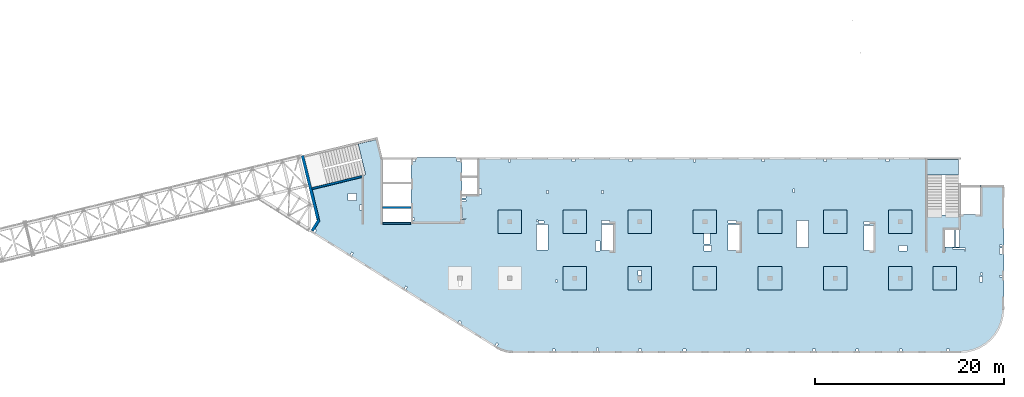
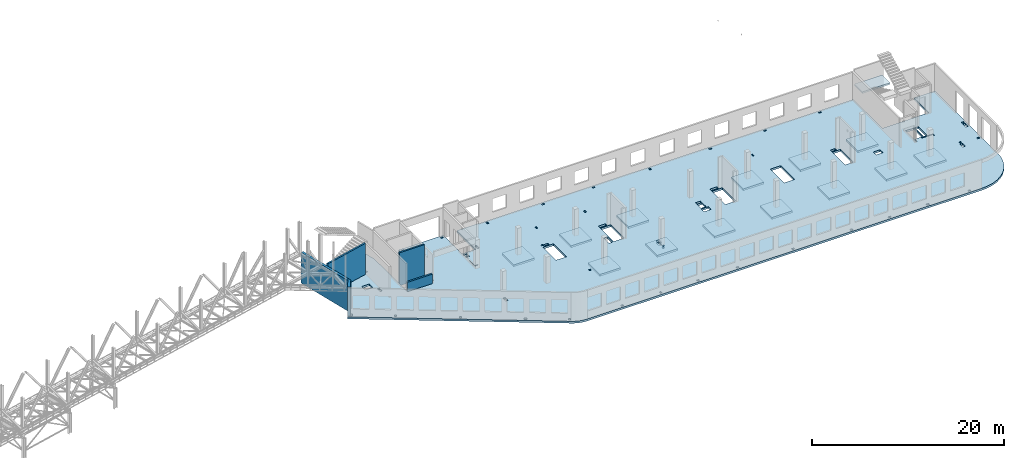
# One storey, part 20 of 93: 16 slabs, 5 walls.
"""IFC4 building model written with IfcOpenShell, lengths in millimetres."""

from ifc_helpers import new_model, entity, si_unit, converted_unit, derived_unit, direction, frame, origin, place, context, subcontext, project, spatial, indexed_curve, outline, extrude, material, type_object, element, save


model = new_model("IFC4")

# Units and contexts
model_context = context("Model", 3, precision=0.01, world=origin(), true_north=direction((6.12303176911189e-17, 1.0)))
plan_context = context("Plan", 3, precision=0.01, world=origin(), true_north=direction((6.12303176911189e-17, 1.0)))
body_context = subcontext(model_context, "Body", "Model", "MODEL_VIEW")
ifc_project = project(units=[si_unit("LENGTHUNIT", "METRE", prefix="MILLI"), si_unit("AREAUNIT", "SQUARE_METRE"), si_unit("VOLUMEUNIT", "CUBIC_METRE"), converted_unit("PLANEANGLEUNIT", "DEGREE", entity("IfcRatioMeasure", 0.0174532925199433), si_unit("PLANEANGLEUNIT", "RADIAN"), dimensions=[0, 0, 0, 0, 0, 0, 0]), si_unit("MASSUNIT", "GRAM", prefix="KILO"), derived_unit("MASSDENSITYUNIT", [(si_unit("MASSUNIT", "GRAM", prefix="KILO"), 1), (si_unit("LENGTHUNIT", "METRE"), -3)]), derived_unit("MOMENTOFINERTIAUNIT", [(si_unit("LENGTHUNIT", "METRE"), 4)]), si_unit("TIMEUNIT", "SECOND"), si_unit("FREQUENCYUNIT", "HERTZ"), si_unit("THERMODYNAMICTEMPERATUREUNIT", "DEGREE_CELSIUS"), derived_unit("THERMALTRANSMITTANCEUNIT", [(si_unit("MASSUNIT", "GRAM", prefix="KILO"), 1), (si_unit("THERMODYNAMICTEMPERATUREUNIT", "KELVIN"), -1), (si_unit("TIMEUNIT", "SECOND"), -3)]), derived_unit("VOLUMETRICFLOWRATEUNIT", [(si_unit("LENGTHUNIT", "METRE"), 3), (si_unit("TIMEUNIT", "SECOND"), -1)]), derived_unit("MASSFLOWRATEUNIT", [(si_unit("MASSUNIT", "GRAM", prefix="KILO"), 1), (si_unit("TIMEUNIT", "SECOND"), -1)]), derived_unit("ROTATIONALFREQUENCYUNIT", [(si_unit("TIMEUNIT", "SECOND"), -1)]), si_unit("ELECTRICCURRENTUNIT", "AMPERE"), si_unit("ELECTRICVOLTAGEUNIT", "VOLT"), si_unit("POWERUNIT", "WATT"), si_unit("FORCEUNIT", "NEWTON", prefix="KILO"), si_unit("ILLUMINANCEUNIT", "LUX"), si_unit("LUMINOUSFLUXUNIT", "LUMEN"), si_unit("LUMINOUSINTENSITYUNIT", "CANDELA"), derived_unit("USERDEFINED", [(si_unit("MASSUNIT", "GRAM", prefix="KILO"), -1), (si_unit("LENGTHUNIT", "METRE"), -2), (si_unit("TIMEUNIT", "SECOND"), 3), (si_unit("LUMINOUSFLUXUNIT", "LUMEN"), 1)]), derived_unit("LINEARVELOCITYUNIT", [(si_unit("LENGTHUNIT", "METRE"), 1), (si_unit("TIMEUNIT", "SECOND"), -1)]), si_unit("PRESSUREUNIT", "PASCAL"), derived_unit("USERDEFINED", [(si_unit("LENGTHUNIT", "METRE"), -2), (si_unit("MASSUNIT", "GRAM", prefix="KILO"), 1), (si_unit("TIMEUNIT", "SECOND"), -2)]), derived_unit("LINEARFORCEUNIT", [(si_unit("MASSUNIT", "GRAM", prefix="KILO"), 1), (si_unit("LENGTHUNIT", "METRE"), 1), (si_unit("TIMEUNIT", "SECOND"), -2), (si_unit("LENGTHUNIT", "METRE"), -1)]), derived_unit("PLANARFORCEUNIT", [(si_unit("MASSUNIT", "GRAM", prefix="KILO"), 1), (si_unit("LENGTHUNIT", "METRE"), 1), (si_unit("TIMEUNIT", "SECOND"), -2), (si_unit("LENGTHUNIT", "METRE"), -2)])], contexts=[model_context, plan_context])

# Site, building, storey
site_placement = place(None, origin())
site = spatial("IfcSite", under=ifc_project, at=site_placement, CompositionType="ELEMENT")
building_placement = place(site_placement, origin())
building = spatial("IfcBuilding", under=site, at=building_placement, CompositionType="ELEMENT")
storey_placement = place(building_placement, frame((0.0, 0.0, 15900.0)))
storey = spatial("IfcBuildingStorey", under=building, at=storey_placement, CompositionType="ELEMENT", Elevation=15900.0)

# Slabs
ifc_material = material()
slab_type_1 = type_object("IfcSlabType", PredefinedType="FLOOR", material=ifc_material)
slab_1_placement = place(storey_placement, origin())
element("IfcSlab", 1, at=slab_1_placement, inside=storey, type_object=slab_type_1, material=ifc_material, PredefinedType="FLOOR", context=body_context, shape_type="SweptSolid", body=[
    extrude(outline(indexed_curve([(-11615.3456191022, -15866.2384672249), (-11461.2227621515, -15956.6617307079), (-11302.2940263976, -16038.3432987954), (-11139.0547290428, -16111.0286027615), (-10972.0136215827, -16174.4911116315), (-10801.6913042325, -16228.5330381886), (-10628.6186034238, -16272.985955397), (-10453.3349174317, -16307.7113213217), (-10276.3865352866, -16332.6009109081), (-10098.3249342096, -16347.5771532763), (-9919.70506087959, -16352.5933734784), (37585.2949391216, -16352.5933734786), (38304.8933503634, -16295.9597502856), (39006.7728605103, -16127.4533884657), (39673.6508666178, -15851.2234738877), (40289.1066189344, -15474.0717038028), (40837.9855542575, -15005.2848064856), (41306.7724515748, -14456.4058711625), (41683.9242216596, -13840.9501188459), (41960.1541362377, -13174.0721127383), (42128.6604980575, -12472.1926025915), (42185.2941212505, -11752.5941913496), (42185.2941212505, 1417.40662652148), (39685.2941212505, 1417.40662652149), (39685.2941212505, -1682.59337347851), (37385.2949391216, -1682.59337347851), (37385.2949391216, -1722.59337347848), (34045.2949391217, -1722.59337347847), (34045.2949391217, 4347.4072658887), (-13659.7050608784, 4347.40726588886), (-13659.7050608784, 447.406626521855), (-15284.7050608784, 447.406626521859), (-15284.7050608784, 4347.40726588869), (-20684.7050608784, 4347.40726588871), (-20684.7050608784, -2502.5933734781), (-23684.7050608784, -2502.59337347809), (-23684.7050608784, 4347.40726588869), (-23734.0606732206, 4347.40726588869), (-24254.10794231, 6480.84192351009), (-24448.4183539383, 6433.47670491202), (-24401.0531353402, 6239.16629328373), (-26276.1486075532, 5782.09193381237), (-25485.1529405355, 2537.12235056864), (-31479.6214345329, 1075.90723492907), (-30648.3195083992, -2334.4141830962), (-31384.8454167592, -3513.12502953493), (-11615.3456191022, -15866.2384672249)], self_intersect=False), holes=[indexed_curve([(-26424.7050608784, -192.593373478052), (-27324.7050608784, -192.593373478052), (-27324.7050608784, 507.406626521949), (-26424.7050608784, 507.406626521947), (-26424.7050608784, -192.593373478052)], self_intersect=False), indexed_curve([(-25884.7050608784, -667.593373478048), (-25884.7050608784, -1227.59337347805), (-26134.7050608784, -1227.59337347805), (-26134.7050608784, -667.593373478048), (-25884.7050608784, -667.593373478048)], self_intersect=False), indexed_curve([(-30865.4736804199, -3248.07220556975), (-30695.8631316644, -3354.05457085215), (-30854.836679588, -3608.47039398543), (-31024.4472283436, -3502.48802870303), (-30865.4736804199, -3248.07220556975)], self_intersect=False), indexed_curve([(-26955.9505316053, -5690.96572532919), (-26786.3399828498, -5796.94809061159), (-26945.3135307734, -6051.36391374487), (-27114.9240795289, -5945.38154846246), (-26955.9505316053, -5690.96572532919)], self_intersect=False), indexed_curve([(-21223.1139836689, -9273.16967187448), (-21053.5034349134, -9379.15203715688), (-21212.476982837, -9633.56786029016), (-21382.0875315925, -9527.58549500775), (-21223.1139836689, -9273.16967187448)], self_intersect=False), indexed_curve([(-15551.7491458115, -12934.8797745334), (-15297.3333226782, -13093.853322457), (-15403.3156879606, -13263.4638712125), (-15657.7315110939, -13104.4903232889), (-15551.7491458115, -12934.8797745334)], self_intersect=False), indexed_curve([(-11580.7542869179, -15298.2671381792), (-11411.1437381624, -15404.2495034616), (-11570.117286086, -15658.6653265949), (-11739.7278348415, -15552.6829613125), (-11580.7542869179, -15298.2671381792)], self_intersect=False), indexed_curve([(-5384.7050608784, -16152.5933734782), (-5684.7050608784, -16152.5933734782), (-5684.7050608784, -15952.5933734782), (-5384.7050608784, -15952.5933734782), (-5384.7050608784, -16152.5933734782)], self_intersect=False), indexed_curve([(-789.705060878393, -16152.5933734782), (-989.705060878395, -16152.5933734782), (-989.705060878386, -15852.5933734782), (-789.705060878388, -15852.5933734782), (-789.705060878393, -16152.5933734782)], self_intersect=False), indexed_curve([(3735.29493912161, -16152.5933734782), (3435.29493912161, -16152.5933734782), (3435.29493912161, -15952.5933734782), (3735.29493912161, -15952.5933734782), (3735.29493912161, -16152.5933734782)], self_intersect=False), indexed_curve([(8485.29493912161, -16152.5933734783), (8185.29493912161, -16152.5933734782), (8185.29493912161, -15952.5933734782), (8485.29493912161, -15952.5933734783), (8485.29493912161, -16152.5933734783)], self_intersect=False), indexed_curve([(15185.2949391216, -16152.5933734783), (14885.2949391216, -16152.5933734782), (14885.2949391216, -15952.5933734783), (15185.2949391216, -15952.5933734783), (15185.2949391216, -16152.5933734783)], self_intersect=False), indexed_curve([(22185.2949391216, -16152.5933734783), (21885.2949391216, -16152.5933734783), (21885.2949391216, -15952.5933734783), (22185.2949391216, -15952.5933734783), (22185.2949391216, -16152.5933734783)], self_intersect=False), indexed_curve([(26785.2949391216, -16152.5933734783), (26485.2949391216, -16152.5933734783), (26485.2949391216, -15952.5933734783), (26785.2949391216, -15952.5933734783), (26785.2949391216, -16152.5933734783)], self_intersect=False), indexed_curve([(31385.2949391216, -16152.5933734783), (31085.2949391216, -16152.5933734783), (31085.2949391216, -15952.5933734783), (31385.2949391216, -15952.5933734783), (31385.2949391216, -16152.5933734783)], self_intersect=False), indexed_curve([(36385.2949391216, -16152.5933734783), (36085.2949391216, -16152.5933734783), (36085.2949391216, -15952.5933734783), (36385.2949391216, -15952.5933734783), (36385.2949391216, -16152.5933734783)], self_intersect=False), indexed_curve([(-20184.7050608784, 4147.4072658887), (-20184.7050608784, 3947.4072658887), (-20484.7050608784, 3947.40726588869), (-20484.7050608784, 4147.4072658887), (-20184.7050608784, 4147.4072658887)], self_intersect=False), indexed_curve([(-20284.7050608784, -2252.59337347809), (-20484.7050608784, -2252.59337347809), (-20484.7050608784, -2052.59337347809), (-20284.7050608784, -2052.59337347809), (-20284.7050608784, -2252.59337347809)], self_intersect=False), indexed_curve([(-15784.7050608784, 4147.4072658887), (-15484.7050608784, 4147.4072658887), (-15484.7050608784, 3947.4072658887), (-15784.7050608784, 3947.4072658887), (-15784.7050608784, 4147.4072658887)], self_intersect=False), indexed_curve([(-14854.7050608784, 247.406626521861), (-14854.7050608784, 47.4066265218589), (-15284.7050608784, 47.4066265218589), (-15284.7050608784, 247.406626521859), (-14854.7050608784, 247.406626521861)], self_intersect=False), indexed_curve([(-14854.7050608784, -177.593373478142), (-14854.7050608784, -337.59337347814), (-15284.7050608784, -337.59337347814), (-15284.7050608784, -177.593373478142), (-14854.7050608784, -177.593373478142)], self_intersect=False), indexed_curve([(-15284.7050608784, -2182.59337347814), (-15284.7050608784, -992.593373478139), (-15204.7050608784, -992.593373478139), (-15204.7050608784, -2102.59337347814), (-14864.7050608784, -2102.59337347814), (-14864.7050608784, -2182.59337347814), (-15284.7050608784, -2182.59337347814)], self_intersect=False), indexed_curve([(-13209.7050608784, 447.406626521855), (-13459.7050608784, 447.406626521855), (-13459.7050608784, 1007.40662652186), (-13209.7050608784, 1007.40662652186), (-13209.7050608784, 447.406626521855)], self_intersect=False), indexed_curve([(-10314.7050608784, 4147.4072658887), (-10214.7050608784, 4147.4072658887), (-10114.7050608784, 4147.40662652183), (-10114.7050608784, 3847.40726588869), (-10314.7050608784, 3847.40726588869), (-10314.7050608784, 4147.4072658887)], self_intersect=False), indexed_curve([(-3614.70506087836, 4147.40662652179), (-3314.70506087836, 4147.40662652179), (-3314.70506087836, 3947.40662652179), (-3614.70506087836, 3947.40662652179), (-3614.70506087836, 4147.40662652179)], self_intersect=False), indexed_curve([(2460.29493912165, 4147.40662652177), (2760.29493912165, 4147.40662652177), (2760.29493912164, 3947.40662652177), (2460.29493912164, 3947.40662652176), (2460.29493912165, 4147.40662652177)], self_intersect=False), indexed_curve([(16510.2949391216, 4147.40662652173), (16810.2949391216, 4147.40662652172), (16810.2949391216, 3947.40662652171), (16510.2949391216, 3947.40662652172), (16510.2949391216, 4147.40662652173)], self_intersect=False), indexed_curve([(9260.29493912165, 4147.4066265217), (9460.29493912165, 4147.4066265217), (9460.29493912166, 3847.4066265217), (9260.29493912165, 3847.4066265217), (9260.29493912165, 4147.4066265217)], self_intersect=False), indexed_curve([(23085.2949391216, 4147.40662652169), (23385.2949391216, 4147.40662652169), (23385.2949391216, 3947.4066265217), (23085.2949391216, 3947.4066265217), (23085.2949391216, 4147.40662652169)], self_intersect=False), indexed_curve([(29685.2949391216, 4147.40662652168), (29985.2949391216, 4147.40662652167), (29985.2949391216, 3947.40662652167), (29685.2949391216, 3947.40662652167), (29685.2949391216, 4147.40662652168)], self_intersect=False), indexed_curve([(-6114.70506087836, 847.407265888692), (-6114.70506087836, 527.407265888689), (-6314.70506087837, 527.407265888691), (-6314.70506087837, 847.407265888695), (-6114.70506087836, 847.407265888692)], self_intersect=False), indexed_curve([(-264.705060878365, 867.407265888811), (-264.70506087836, 507.407265888813), (-464.705060878358, 507.407265888813), (-464.705060878358, 867.407265888811), (-264.705060878365, 867.407265888811)], self_intersect=False), indexed_curve([(19975.2949391216, 997.407265888704), (19975.2949391216, 647.407265888701), (19825.2949391216, 647.407265888701), (19825.2949391216, 997.407265888704), (19975.2949391216, 997.407265888704)], self_intersect=False), indexed_curve([(37055.2949391217, -5127.59337347849), (37055.2949391217, -3322.59337347848), (37385.2949391216, -3322.59337347849), (37445.2949391217, -3322.59337347849), (37445.2949391217, -5127.59337347849), (37055.2949391217, -5127.59337347849)], self_intersect=False), indexed_curve([(35975.2949391217, -5247.59337347849), (35975.2949391217, -5587.59337347849), (35895.2949391217, -5587.59337347849), (35895.2949391217, -5247.59337347849), (35975.2949391217, -5247.59337347849)], self_intersect=False), indexed_curve([(38095.2949391216, -5247.59337347848), (38095.2949391216, -5587.59337347848), (38015.2949391216, -5587.59337347849), (38015.2949391216, -5327.59337347848), (36715.2949391216, -5327.59337347848), (36715.2949391216, -5247.59337347849), (38095.2949391216, -5247.59337347848)], self_intersect=False), indexed_curve([(41685.2941212505, -8342.59337347853), (41685.2941212505, -8142.59337347853), (41985.2941212505, -8142.59337347853), (41985.2941212505, -8342.59337347853), (41685.2941212505, -8342.59337347853)], self_intersect=False), indexed_curve([(41685.2941212505, -5102.59337347853), (41685.2941212505, -4902.59337347852), (41985.2941212505, -4902.59337347853), (41985.2941212505, -5102.59337347853), (41685.2941212505, -5102.59337347853)], self_intersect=False), indexed_curve([(41685.2941212505, -5867.59337347854), (41685.2941212505, -5267.59337347853), (41985.2941212505, -5267.59337347854), (41985.2941212505, -5867.59337347854), (41685.2941212505, -5867.59337347854)], self_intersect=False), indexed_curve([(39895.2941212505, -8272.5933734785), (39895.2941212505, -8852.59337347852), (39595.2941212505, -8852.59337347852), (39595.2941212505, -8272.59337347851), (39895.2941212505, -8272.5933734785)], self_intersect=False), indexed_curve([(39905.2941212505, -7892.59337347851), (39905.2941212505, -8092.59337347851), (39705.2941212505, -8092.59337347851), (39705.2941212505, -7892.5933734785), (39905.2941212505, -7892.59337347851)], self_intersect=False), indexed_curve([(31900.2949391216, -4967.59337347845), (31900.2949391216, -5567.59337347845), (31070.2949391216, -5567.59337347845), (31070.2949391216, -4967.59337347845), (31900.2949391216, -4967.59337347845)], self_intersect=False), indexed_curve([(27345.2949391216, -5527.59337347843), (27345.2949391216, -2857.59337347842), (28345.2949391217, -2857.59337347842), (28345.2949391217, -5527.59337347844), (27345.2949391216, -5527.59337347843)], self_intersect=False), indexed_curve([(27345.2949391216, -2452.59337347842), (27945.2949391216, -2452.59337347842), (27945.2949391216, -2737.59337347842), (27345.2949391216, -2737.59337347842), (27345.2949391216, -2452.59337347842)], self_intersect=False), indexed_curve([(21465.2949391216, -2317.59337347838), (21465.2949391216, -5177.59337347839), (20205.2949391216, -5177.59337347839), (20205.2949391216, -2317.59337347838), (21465.2949391216, -2317.59337347838)], self_intersect=False), indexed_curve([(12925.2949391216, -5527.59322391854), (12925.2949391216, -2752.59322391854), (14185.2949391216, -2752.59322391854), (14185.2949391216, -5527.59322391853), (12925.2949391216, -5527.59322391854)], self_intersect=False), indexed_curve([(12925.2949391216, -2602.59337347834), (12925.2949391216, -2312.59337347833), (13785.2949391216, -2312.59337347833), (13785.2949391216, -2602.59337347834), (12925.2949391216, -2602.59337347834)], self_intersect=False), indexed_curve([(10395.2949391217, -3702.59337347839), (10485.2949391216, -3702.59337347838), (11015.2949391216, -3702.59337347839), (11015.2949391216, -4822.59337347839), (10395.2949391217, -4822.59337347839), (10395.2949391217, -3702.59337347839)], self_intersect=False), indexed_curve([(10370.2949391216, -4967.59337347839), (11200.2949391216, -4967.59337347839), (11200.2949391216, -5567.59337347838), (10370.2949391216, -5567.59337347839), (10370.2949391216, -4967.59337347839)], self_intersect=False), indexed_curve([(3485.29493912162, -8702.59337347826), (3585.29493912162, -8702.59337347826), (3685.29493912163, -8702.59337347826), (3685.29493912163, -8902.59337347827), (3485.29493912163, -8902.59337347827), (3485.29493912162, -8702.59337347826)], self_intersect=False), indexed_curve([(3405.29493912162, -8162.59337347827), (3405.29493912162, -7652.59337347826), (3735.29493912162, -7652.59337347827), (3735.29493912162, -8162.59337347826), (3405.29493912162, -8162.59337347827)], self_intersect=False), indexed_curve([(-474.705060878365, -5527.5932239185), (-474.705060878365, -2752.5932239185), (785.29493912163, -2752.5932239185), (785.294939121635, -5527.59322391849), (-474.705060878365, -5527.5932239185)], self_intersect=False), indexed_curve([(-474.705060878365, -2312.59337347824), (385.29493912163, -2312.59337347824), (385.294939121626, -2632.59337347824), (-474.705060878369, -2632.59337347824), (-474.705060878365, -2312.59337347824)], self_intersect=False), indexed_curve([(-1094.70506087836, -5567.5932239185), (-1094.70506087837, -4477.5932239185), (-634.705060878363, -4477.5932239185), (-634.705060878363, -5567.5932239185), (-1094.70506087836, -5567.5932239185)], self_intersect=False), indexed_curve([(-5134.70506087838, -8662.5933734782), (-5134.70506087839, -8862.5933734782), (-5334.70506087839, -8862.5933734782), (-5334.70506087839, -8662.5933734782), (-5134.70506087838, -8662.5933734782)], self_intersect=False), indexed_curve([(-6134.70506087837, -2752.59337347818), (-6134.70506087837, -5462.59337347818), (-7394.70506087837, -5462.59337347818), (-7394.70506087837, -2752.59337347818), (-6134.70506087837, -2752.59337347818)], self_intersect=False), indexed_curve([(-7194.70506087837, -2462.59337347819), (-7394.70506087837, -2462.59337347819), (-7394.70506087837, -2272.59337347818), (-7194.70506087837, -2272.59337347818), (-7194.70506087837, -2462.59337347819)], self_intersect=False), indexed_curve([(-6594.70506087837, -2632.59337347819), (-7154.70506087837, -2632.59337347819), (-7154.70506087837, -2382.5933734782), (-6594.70506087837, -2382.5933734782), (-6594.70506087837, -2632.59337347819)], self_intersect=False), indexed_curve([(36935.2949391217, -3322.59337347849), (36935.2949391217, -5127.59337347849), (35895.2949391217, -5127.59337347849), (35895.2949391217, -3322.59337347849), (36935.2949391217, -3322.59337347849)], self_intersect=False), indexed_curve([(-15644.7050608784, -8702.59337347814), (-15484.7050608784, -8702.59337347813), (-15394.7050608784, -8702.59337347813), (-15394.7050608784, -9262.59337347813), (-15644.7050608784, -9262.59337347814), (-15644.7050608784, -8702.59337347814)], self_intersect=False)]), frame((31384.7053294331, 16152.592599834, -400.0)), (0.0, 0.0, 1.0), 249.999999999999),
])
slab_type_2 = type_object("IfcSlabType", PredefinedType="FLOOR", material=ifc_material)
slab_2_placement = place(storey_placement, origin())
element("IfcSlab", 2, at=slab_2_placement, inside=storey, type_object=slab_type_2, material=ifc_material, PredefinedType="FLOOR", context=body_context, shape_type="SweptSolid", body=[
    extrude(outline(indexed_curve([(-1250.0, -1250.0), (1250.0, -1250.0), (1250.0, 1250.0), (-1250.0, 1250.0), (-1250.0, -1250.0)], self_intersect=False)), frame((28070.0002685547, 7699.9992263558, -400.0), z_axis=(0.0, 0.0, -1.0), x_axis=(0.0, 1.0, 0.0)), (0.0, 0.0, 1.0), 249.999999999999),
])
slab_type_3 = type_object("IfcSlabType", PredefinedType="FLOOR", material=ifc_material)
slab_3_placement = place(storey_placement, origin())
element("IfcSlab", 3, at=slab_3_placement, inside=storey, type_object=slab_type_3, material=ifc_material, PredefinedType="FLOOR", context=body_context, shape_type="SweptSolid", body=[
    extrude(outline(indexed_curve([(-999.999999999999, -1250.00000000001), (1500.0, -1250.00000000001), (1500.0, 1250.0), (-999.999999999999, 1250.0), (-1000.0, -6.064055924071e-12), (-999.999999999999, -1250.00000000001)], self_intersect=False), holes=[indexed_curve([(500.000000000073, 99.9999999999998), (700.000000000076, 100.0), (700.000000000076, -100.000000000002), (500.000000000074, -100.000000000002), (500.000000000073, 99.9999999999998)], self_intersect=False), indexed_curve([(-549.999999999928, 149.999999999991), (-39.9999999999262, 149.999999999992), (-39.9999999999256, -180.000000000007), (-549.999999999928, -180.000000000008), (-549.999999999928, 149.999999999991)], self_intersect=False)]), frame((34970.0002685547, 7949.99922635578, -650.0), z_axis=(0.0, 0.0, 1.0), x_axis=(0.0, -1.0, 0.0)), (0.0, 0.0, 1.0), 249.999999999999),
])
slab_type_4 = type_object("IfcSlabType", PredefinedType="FLOOR", material=ifc_material)
slab_4_placement = place(storey_placement, origin())
element("IfcSlab", 4, at=slab_4_placement, inside=storey, type_object=slab_type_4, material=ifc_material, PredefinedType="FLOOR", context=body_context, shape_type="SweptSolid", body=[
    extrude(outline(indexed_curve([(-1250.0, -1250.0), (1250.0, -1250.0), (1250.0, 1250.0), (-1250.0, 1250.0), (-1250.0, -1250.0)], self_intersect=False)), frame((41870.0002685547, 7699.99922635575, -400.0), z_axis=(0.0, 0.0, -1.0), x_axis=(0.0, 1.0, 0.0)), (0.0, 0.0, 1.0), 249.999999999999),
])
slab_type_5 = type_object("IfcSlabType", PredefinedType="FLOOR", material=ifc_material)
slab_5_placement = place(storey_placement, origin())
element("IfcSlab", 5, at=slab_5_placement, inside=storey, type_object=slab_type_5, material=ifc_material, PredefinedType="FLOOR", context=body_context, shape_type="SweptSolid", body=[
    extrude(outline(indexed_curve([(-1250.0, -1250.0), (1250.0, -1250.0), (1250.0, 1250.0), (-1250.0, 1250.0), (-1250.0, -1250.0)], self_intersect=False)), frame((48770.0002685547, 7699.99922635573, -400.0), z_axis=(0.0, 0.0, -1.0), x_axis=(0.0, 1.0, 0.0)), (0.0, 0.0, 1.0), 249.999999999999),
])
slab_type_6 = type_object("IfcSlabType", PredefinedType="FLOOR", material=ifc_material)
slab_6_placement = place(storey_placement, origin())
element("IfcSlab", 6, at=slab_6_placement, inside=storey, type_object=slab_type_6, material=ifc_material, PredefinedType="FLOOR", context=body_context, shape_type="SweptSolid", body=[
    extrude(outline(indexed_curve([(-1250.0, -1249.99999999999), (1250.0, -1249.99999999999), (1250.0, 1250.00000000001), (-1250.0, 1250.00000000001), (-1250.0, -1249.99999999999)], self_intersect=False)), frame((55670.0002685547, 7699.99922635571, -400.0), z_axis=(0.0, 0.0, -1.0), x_axis=(0.0, 1.0, 0.0)), (0.0, 0.0, 1.0), 249.999999999999),
])
slab_type_7 = type_object("IfcSlabType", PredefinedType="FLOOR", material=ifc_material)
slab_7_placement = place(storey_placement, origin())
element("IfcSlab", 7, at=slab_7_placement, inside=storey, type_object=slab_type_7, material=ifc_material, PredefinedType="FLOOR", context=body_context, shape_type="SweptSolid", body=[
    extrude(outline(indexed_curve([(-1250.0, -1250.0), (1250.0, -1250.0), (1250.0, 1250.0), (-1250.0, 1250.0), (-1250.0, -1250.0)], self_intersect=False)), frame((62570.0002685547, 7699.99922635568, -400.0), z_axis=(0.0, 0.0, -1.0), x_axis=(0.0, 1.0, 0.0)), (0.0, 0.0, 1.0), 249.999999999999),
])
slab_type_8 = type_object("IfcSlabType", PredefinedType="FLOOR", material=ifc_material)
slab_8_placement = place(storey_placement, origin())
element("IfcSlab", 8, at=slab_8_placement, inside=storey, type_object=slab_type_8, material=ifc_material, PredefinedType="FLOOR", context=body_context, shape_type="SweptSolid", body=[
    extrude(outline(indexed_curve([(-1250.0, -1249.99999999999), (1250.0, -1249.99999999999), (1250.0, 1250.00000000001), (-1250.0, 1250.00000000001), (-1250.0, -1249.99999999999)], self_intersect=False)), frame((67270.0002685547, 7699.99922635567, -400.0), z_axis=(0.0, 0.0, -1.0), x_axis=(0.0, 1.0, 0.0)), (0.0, 0.0, 1.0), 249.999999999999),
])
slab_type_9 = type_object("IfcSlabType", PredefinedType="FLOOR", material=ifc_material)
slab_9_placement = place(storey_placement, origin())
element("IfcSlab", 9, at=slab_9_placement, inside=storey, type_object=slab_type_9, material=ifc_material, PredefinedType="FLOOR", context=body_context, shape_type="SweptSolid", body=[
    extrude(outline(indexed_curve([(-1250.0, -1250.0), (1250.0, -1250.0), (1250.0, 1250.0), (-1250.0, 1250.0), (-1250.0, -1250.0)], self_intersect=False)), frame((62570.0002685547, 13699.9992263555, -400.0), z_axis=(0.0, 0.0, -1.0), x_axis=(0.0, 1.0, 0.0)), (0.0, 0.0, 1.0), 249.999999999999),
])
slab_type_10 = type_object("IfcSlabType", PredefinedType="FLOOR", material=ifc_material)
slab_10_placement = place(storey_placement, origin())
element("IfcSlab", 10, at=slab_10_placement, inside=storey, type_object=slab_type_10, material=ifc_material, PredefinedType="FLOOR", context=body_context, shape_type="SweptSolid", body=[
    extrude(outline(indexed_curve([(-1250.0, -1250.0), (1250.0, -1250.0), (1250.0, 1250.0), (-1250.0, 1250.0), (-1250.0, -1250.0)], self_intersect=False)), frame((55670.0002685547, 13699.9992263555, -400.0), z_axis=(0.0, 0.0, -1.0), x_axis=(0.0, 1.0, 0.0)), (0.0, 0.0, 1.0), 249.999999999999),
])
slab_type_11 = type_object("IfcSlabType", PredefinedType="FLOOR", material=ifc_material)
slab_11_placement = place(storey_placement, origin())
element("IfcSlab", 11, at=slab_11_placement, inside=storey, type_object=slab_type_11, material=ifc_material, PredefinedType="FLOOR", context=body_context, shape_type="SweptSolid", body=[
    extrude(outline(indexed_curve([(-1250.0, -1250.0), (1250.0, -1250.0), (1250.0, 1250.0), (-1250.0, 1250.0), (-1250.0, -1250.0)], self_intersect=False)), frame((48770.0002685547, 13699.9992263556, -400.0), z_axis=(0.0, 0.0, -1.0), x_axis=(0.0, 1.0, 0.0)), (0.0, 0.0, 1.0), 249.999999999999),
])
slab_type_12 = type_object("IfcSlabType", PredefinedType="FLOOR", material=ifc_material)
slab_12_placement = place(storey_placement, origin())
element("IfcSlab", 12, at=slab_12_placement, inside=storey, type_object=slab_type_12, material=ifc_material, PredefinedType="FLOOR", context=body_context, shape_type="SweptSolid", body=[
    extrude(outline(indexed_curve([(-1250.0, -1250.0), (1250.0, -1250.0), (1250.0, 1250.0), (-1250.0, 1250.0), (-1250.0, -1250.0)], self_intersect=False)), frame((41870.0002685547, 13699.9992263556, -400.0), z_axis=(0.0, 0.0, -1.0), x_axis=(0.0, 1.0, 0.0)), (0.0, 0.0, 1.0), 249.999999999999),
])
slab_type_13 = type_object("IfcSlabType", PredefinedType="FLOOR", material=ifc_material)
slab_13_placement = place(storey_placement, origin())
element("IfcSlab", 13, at=slab_13_placement, inside=storey, type_object=slab_type_13, material=ifc_material, PredefinedType="FLOOR", context=body_context, shape_type="SweptSolid", body=[
    extrude(outline(indexed_curve([(-1250.0, -1250.0), (1250.0, -1250.0), (1250.0, 1250.0), (-1250.0, 1250.0), (-1250.0, -1250.0)], self_intersect=False)), frame((34970.0002685547, 13699.9992263556, -400.0), z_axis=(0.0, 0.0, -1.0), x_axis=(0.0, 1.0, 0.0)), (0.0, 0.0, 1.0), 249.999999999999),
])
slab_type_14 = type_object("IfcSlabType", PredefinedType="FLOOR", material=ifc_material)
slab_14_placement = place(storey_placement, origin())
element("IfcSlab", 14, at=slab_14_placement, inside=storey, type_object=slab_type_14, material=ifc_material, PredefinedType="FLOOR", context=body_context, shape_type="SweptSolid", body=[
    extrude(outline(indexed_curve([(-1250.0, -1250.0), (1250.0, -1250.0), (1250.0, 1250.0), (-1250.0, 1250.0), (-1250.0, -1250.0)], self_intersect=False)), frame((28070.0002685547, 13699.9992263556, -400.0), z_axis=(0.0, 0.0, -1.0), x_axis=(0.0, 1.0, 0.0)), (0.0, 0.0, 1.0), 249.999999999999),
])
slab_type_15 = type_object("IfcSlabType", PredefinedType="FLOOR", material=ifc_material)
slab_15_placement = place(storey_placement, origin())
element("IfcSlab", 15, at=slab_15_placement, inside=storey, type_object=slab_type_15, material=ifc_material, PredefinedType="FLOOR", context=body_context, shape_type="SweptSolid", body=[
    extrude(outline(indexed_curve([(-1250.0, -1250.0), (1250.0, -1250.0), (1250.0, 1250.0), (-1250.0, 1250.0), (-1250.0, -1250.0)], self_intersect=False)), frame((21170.0002685547, 13699.9992263556, -400.0), z_axis=(0.0, 0.0, -1.0), x_axis=(0.0, 1.0, 0.0)), (0.0, 0.0, 1.0), 249.999999999999),
])
slab_type_16 = type_object("IfcSlabType", PredefinedType="FLOOR", material=ifc_material)
slab_16_placement = place(storey_placement, origin())
element("IfcSlab", 16, at=slab_16_placement, inside=storey, type_object=slab_type_16, material=ifc_material, PredefinedType="FLOOR", context=body_context, shape_type="SweptSolid", body=[
    extrude(outline(indexed_curve([(-834.999999999999, -1670.00000000001), (835.000000000001, -1670.00000000001), (835.000000000001, 1670.00000000002), (-834.999999999999, 1670.00000000002), (-834.999999999999, -1670.00000000001)], self_intersect=False)), frame((67100.0002685547, 19464.999226356, 1920.0), z_axis=(0.0, 0.0, -1.0), x_axis=(0.0, 1.0, 0.0)), (0.0, 0.0, 1.0), 200.0),
])

# Walls
wall_type_1 = type_object("IfcWallType", PredefinedType="STANDARD")
wall_1_placement = place(storey_placement, frame((220.235605211588, 17202.3781658972, -150.0), z_axis=(0.0, 0.0, 1.0), x_axis=(0.971552058141473, 0.236826092990338, 0.0)))
element("IfcWall", 17, at=wall_1_placement, inside=storey, type_object=wall_type_1, material=ifc_material, PredefinedType="NOTDEFINED", context=body_context, shape_type="SweptSolid", body=[
    extrude(outline(indexed_curve([(5409.98499256816, -99.9999999999997), (5458.73710852649, 100.000000000002), (6.34492458573277e-13, 100.000000000002), (1.7427392862146e-12, -99.9999999999982), (5409.98499256816, -99.9999999999997)], self_intersect=False)), origin(), (0.0, 0.0, 1.0), 3950.0),
])
wall_2_placement = place(storey_placement, frame((7700.00026855469, 15199.9998657227, -400.0)))
element("IfcWall", 18, at=wall_2_placement, inside=storey, type_object=wall_type_1, material=ifc_material, PredefinedType="NOTDEFINED", context=body_context, shape_type="SweptSolid", body=[
    extrude(outline(indexed_curve([(3000.0, 99.9999999999989), (-2.88764567812902e-13, 99.9999999999989), (2.88764567812902e-13, -99.9999999999989), (3000.0, -99.9999999999989), (3000.0, 99.9999999999989)], self_intersect=False)), origin(), (0.0, 0.0, 1.0), 4200.0),
])
wall_3_placement = place(storey_placement, frame((7700.00026855469, 13549.9992263559, -150.0)))
element("IfcWall", 19, at=wall_3_placement, inside=storey, type_object=wall_type_1, material=ifc_material, PredefinedType="NOTDEFINED", context=body_context, shape_type="SweptSolid", body=[
    extrude(outline(indexed_curve([(3000.0, 99.9999999999989), (-2.88764567812902e-13, 99.9999999999989), (2.88764567812902e-13, -99.9999999999989), (3000.0, -99.9999999999989), (3000.0, 99.9999999999989)], self_intersect=False)), origin(), (0.0, 0.0, 1.0), 1200.0),
])
wall_type_2 = type_object("IfcWallType", PredefinedType="STANDARD")
wall_4_placement = place(storey_placement, frame((233.05018952286, 12729.5913450927, -150.0), z_axis=(0.0, 0.0, 1.0), x_axis=(0.529911826412024, 0.848052743777575, 0.0)))
element("IfcWall", 20, at=wall_4_placement, inside=storey, type_object=wall_type_2, material=ifc_material, PredefinedType="NOTDEFINED", context=body_context, shape_type="SweptSolid", body=[
    extrude(outline(indexed_curve([(1316.31557757947, -150.0), (1609.08571844498, 150.0), (2.08113526412035e-12, 150.0), (9.05209240897875e-13, -150.0), (1316.31557757947, -150.0)], self_intersect=False)), origin(), (0.0, 0.0, 1.0), 3650.0),
])
wall_5_placement = place(storey_placement, frame((-787.544181994463, 20703.3037435836, -400.0), z_axis=(0.0, 0.0, 1.0), x_axis=(0.236826092990339, -0.971552058141473, 0.0)))
element("IfcWall", 21, at=wall_5_placement, inside=storey, type_object=wall_type_2, material=ifc_material, PredefinedType="NOTDEFINED", context=body_context, shape_type="SweptSolid", body=[
    extrude(outline(indexed_curve([(7050.16407046696, -150.0), (6757.39392960146, 150.0), (-2.49567033705489e-13, 150.0), (1.86117787848161e-13, -150.0), (7050.16407046696, -150.0)], self_intersect=False)), origin(), (0.0, 0.0, 1.0), 3900.0),
])

save(model, "model.ifc")
